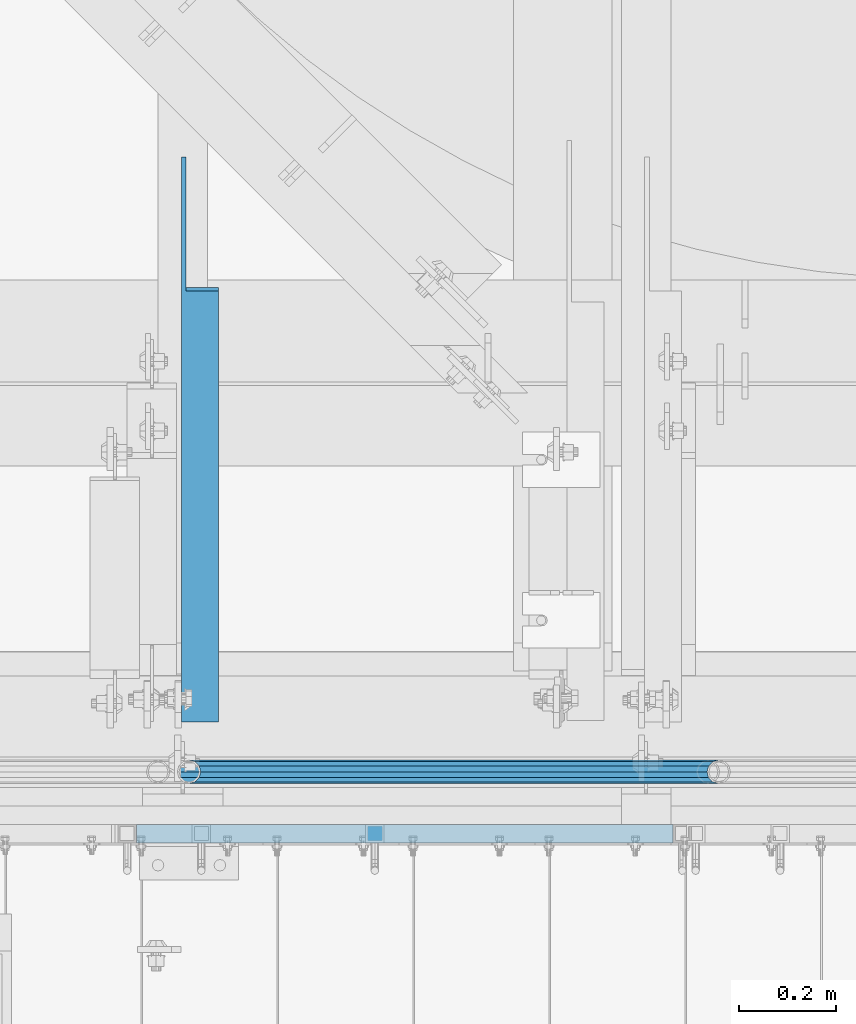
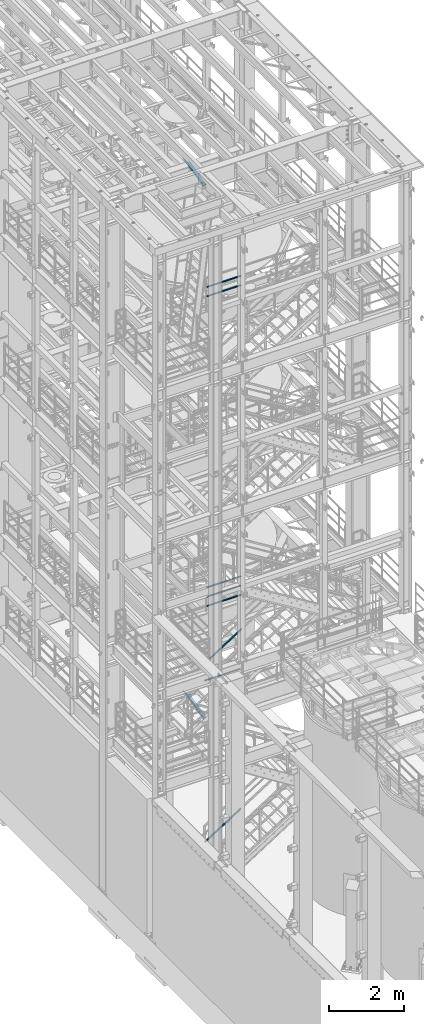
# One storey, part 969 of 1876: 8 beams, 2 members, 7 elements without a shape of their own.
"""IFC2X3 building model written with IfcOpenShell, lengths in millimetres."""

from ifc_helpers import new_model, si_unit, frame, origin_with_axes, place, context, subcontext, project, spatial, faceted_brep, material, type_object, element, aggregate, save


model = new_model("IFC2X3")

# Units and contexts
model_context = context("Model", 3, precision=1e-05, world=origin_with_axes())
body_context = subcontext(model_context, "Body", "Model", "MODEL_VIEW")
ifc_project = project(units=[si_unit("LENGTHUNIT", "METRE", prefix="MILLI"), si_unit("AREAUNIT", "SQUARE_METRE"), si_unit("VOLUMEUNIT", "CUBIC_METRE"), si_unit("MASSUNIT", "GRAM", prefix="KILO"), si_unit("TIMEUNIT", "SECOND"), si_unit("PLANEANGLEUNIT", "RADIAN"), si_unit("SOLIDANGLEUNIT", "STERADIAN"), si_unit("THERMODYNAMICTEMPERATUREUNIT", "DEGREE_CELSIUS"), si_unit("LUMINOUSINTENSITYUNIT", "LUMEN")], contexts=[model_context])

# Site, building, storey
site_placement = place(None, origin_with_axes())
site = spatial("IfcSite", under=ifc_project, at=site_placement, CompositionType="ELEMENT")
building_placement = place(site_placement, origin_with_axes())
building = spatial("IfcBuilding", under=site, at=building_placement, Name="Undefined", CompositionType="ELEMENT")
storey_placement = place(building_placement, origin_with_axes())
storey = spatial("IfcBuildingStorey", under=building, at=storey_placement, Name="Undefined", CompositionType="ELEMENT", Elevation=0.0)

# Assembly, beam
assembly_1_placement = place(storey_placement, origin_with_axes())
assembly_1 = element("IfcElementAssembly", 1, at=assembly_1_placement, inside=storey, Name="RAIL", AssemblyPlace="NOTDEFINED", PredefinedType="RIGID_FRAME")
ifc_material_1 = material()
beam_type_1 = type_object("IfcBeamType", Name="PIPE1-1/2SCH40", PredefinedType="NOTDEFINED")
beam_1_placement = place(assembly_1_placement, frame((2870.19999998823, -4654.55000114554, 18449.925), z_axis=(0.0, 0.0, -1.0), x_axis=(1.0, 0.0, 0.0)))
beam_1 = element("IfcBeam", 2, at=beam_1_placement, type_object=beam_type_1, material=ifc_material_1, Name="RAIL", ObjectType="PIPE1-1/2SCH40", context=body_context, shape_type="Brep", body=[
    faceted_brep([(0.0, 24.1299999999992, 0.0), (12.0650000000064, 20.8971929933177, -12.0649999999987), (12.0650000000064, 20.8971929933177, 12.0649999999987), (12.0650000000064, -20.8971929933177, 12.0649999999987), (12.0650000000064, -20.8971929933177, -12.0649999999987), (0.0, -24.1299999999992, 0.0), (20.8971929933249, -12.0650000000005, 20.8971929933177), (20.8971929933249, -12.0650000000005, 15.8661214311796), (15.2545715621445, -17.7076214311801, 10.2235000000001), (12.5151929933249, -20.4470000000001, 0.0), (15.2545715621445, -17.7076214311801, -10.2235000000001), (20.8971929933249, -12.0650000000005, -15.8661214311796), (20.8971929933249, -12.0650000000005, -20.8971929933177), (24.1300000000063, 0.0, -20.4470000000001), (24.1300000000063, 0.0, -24.130000000001), (21.3906214311868, -10.2235000000001, -17.7076214311819), (21.3906214311868, 10.2235000000001, -17.7076214311819), (20.8971929933249, 12.0650000000005, -15.8661214311796), (20.8971929933249, 12.0650000000005, -20.8971929933177), (15.2545715621445, 17.7076214311801, -10.2235000000001), (12.5151929933249, 20.4470000000001, 0.0), (15.2545715621445, 17.7076214311801, 10.2235000000001), (20.8971929933249, 12.0650000000005, 15.8661214311796), (20.8971929933249, 12.0650000000005, 20.8971929933177), (21.3906214311868, 10.2235000000001, 17.7076214311819), (24.1300000000064, 0.0, 20.4470000000001), (24.1300000000064, 0.0, 24.130000000001), (21.3906214311868, -10.2235000000001, 17.7076214311819), (1089.02499998822, 24.1300000000001, 0.0), (1076.95999998821, 20.8971929933186, -12.0650000000005), (1068.12780699489, 12.0649999999996, -20.8971929933177), (1089.02499998821, -24.1299999999865, 0.0), (1076.95999998821, -20.8971929933186, -12.0650000000005), (1076.95999998821, -20.8971929933186, 12.0650000000005), (1068.12780699489, -12.0649999999996, 20.8971929933177), (1068.12780699489, -12.0649999999996, -20.8971929933177), (1064.89499998821, 0.0, -24.1299999999992), (1067.63437855703, 10.2235000000001, -17.7076214311801), (1064.89499998821, 0.0, -20.4470000000001), (1068.12780699489, 12.0650000000132, -15.8661214311669), (1068.12780699489, -12.064999999986, -15.8661214311942), (1067.63437855703, -10.2235000000001, -17.7076214311801), (1073.77042842609, -17.7076214311801, -10.2235000000001), (1076.50980699491, -20.4470000000001, 0.0), (1073.77042842609, -17.7076214311801, 10.2235000000001), (1068.12780699489, -12.064999999986, 15.8661214311942), (1067.63437855703, -10.2235000000001, 17.7076214311801), (1064.89499998821, 0.0, 20.4470000000001), (1064.89499998821, 0.0, 24.1299999999992), (1068.12780699489, 12.0649999999996, 20.8971929933177), (1076.95999998821, 20.8971929933186, 12.0650000000005), (1068.12780699489, 12.0650000000132, 15.8661214311669), (1073.77042842606, 17.7076214311801, 10.2235000000001), (1076.50980699488, 20.4470000000001, 0.0), (1073.77042842606, 17.7076214311801, -10.2235000000001), (1067.63437855703, 10.2235000000001, 17.7076214311801)], [[[0, 1, 2]], [[3, 4, 5]], [[6, 7, 8, 9, 10, 11, 12, 4, 3]], [[13, 14, 12, 11, 15]], [[16, 17, 18, 14, 13]], [[2, 1, 18, 17, 19, 20, 21, 22, 23]], [[23, 22, 24, 25, 26]], [[26, 25, 27, 7, 6]], [[1, 0, 28, 29]], [[18, 1, 29, 30]], [[31, 32, 33]], [[6, 3, 33, 34]], [[3, 5, 31, 33]], [[5, 4, 32, 31]], [[4, 12, 35, 32]], [[12, 14, 36, 35]], [[14, 18, 30, 36]], [[37, 38, 36, 30, 39]], [[40, 35, 36, 38, 41]], [[33, 32, 35, 40, 42, 43, 44, 45, 34]], [[34, 45, 46, 47, 48]], [[26, 6, 34, 48]], [[2, 23, 49, 50]], [[23, 26, 48, 49]], [[0, 2, 50, 28]], [[28, 50, 29]], [[49, 51, 52, 53, 54, 39, 30, 29, 50]], [[48, 47, 55, 51, 49]], [[25, 24, 55, 47]], [[55, 24, 22, 21, 52, 51]], [[21, 20, 53, 52]], [[20, 19, 54, 53]], [[19, 17, 16, 37, 39, 54]], [[16, 13, 38, 37]], [[13, 15, 41, 38]], [[41, 15, 11, 10, 42, 40]], [[10, 9, 43, 42]], [[9, 8, 44, 43]], [[8, 7, 27, 46, 45, 44]], [[27, 25, 47, 46]]]),
])

# Assembly, beams
assembly_2_placement = place(storey_placement, origin_with_axes())
assembly_2 = element("IfcElementAssembly", 3, at=assembly_2_placement, inside=storey, Name="RAIL", AssemblyPlace="NOTDEFINED", PredefinedType="RIGID_FRAME")
beam_2_placement = place(assembly_2_placement, frame((3959.22499997646, -4654.55000114554, 8315.325), z_axis=(0.0, 0.0, 1.0), x_axis=(-1.0, 0.0, 0.0)))
beam_2 = element("IfcBeam", 4, at=beam_2_placement, type_object=beam_type_1, material=ifc_material_1, Name="RAIL", ObjectType="PIPE1-1/2SCH40", context=body_context, shape_type="Brep", body=[
    faceted_brep([(1068.12780699489, -12.0649999999996, 20.8971929933177), (1068.12780699489, -12.064999999986, 15.8661214311942), (1067.63437855703, -10.2235000000001, 17.7076214311801), (1064.89499998821, 0.0, 20.4470000000001), (1064.89499998821, 0.0, 24.1299999999992), (1067.63437855703, 10.2235000000001, 17.7076214311801), (1068.12780699489, 12.0650000000132, 15.8661214311669), (1068.12780699489, 12.0649999999996, 20.8971929933177), (1089.02499998822, 24.1300000000001, 0.0), (1076.95999998821, 20.8971929933186, 12.0650000000005), (1076.95999998821, 20.8971929933186, -12.0650000000005), (1073.77042842606, 17.7076214311801, 10.2235000000001), (1076.50980699488, 20.4470000000001, 0.0), (1073.77042842606, 17.7076214311801, -10.2235000000001), (1068.12780699489, 12.0650000000132, -15.8661214311669), (1068.12780699489, 12.0649999999996, -20.8971929933177), (1067.63437855703, 10.2235000000001, -17.7076214311801), (1064.89499998821, 0.0, -20.4470000000001), (1064.89499998821, 0.0, -24.1299999999992), (1068.12780699489, -12.064999999986, -15.8661214311942), (1068.12780699489, -12.0649999999996, -20.8971929933177), (1067.63437855703, -10.2235000000001, -17.7076214311801), (1089.02499998821, -24.1299999999865, 0.0), (1076.95999998821, -20.8971929933186, -12.0650000000005), (1076.95999998821, -20.8971929933186, 12.0650000000005), (1073.77042842609, -17.7076214311801, -10.2235000000001), (1076.50980699491, -20.4470000000001, 0.0), (1073.77042842609, -17.7076214311801, 10.2235000000001), (12.0650000000064, -20.8971929933177, -12.0649999999987), (20.8971929933249, -12.0650000000005, -20.8971929933177), (0.0, 24.1299999999992, 0.0), (12.0650000000064, 20.8971929933177, -12.0649999999987), (12.0650000000064, 20.8971929933177, 12.0649999999987), (20.8971929933249, 12.0650000000005, 20.8971929933177), (24.1300000000064, 0.0, 24.130000000001), (20.8971929933249, 12.0650000000005, -20.8971929933177), (24.1300000000063, 0.0, -24.130000000001), (24.1300000000063, 0.0, -20.4470000000001), (20.8971929933249, -12.0650000000005, -15.8661214311796), (21.3906214311868, -10.2235000000001, -17.7076214311819), (21.3906214311868, 10.2235000000001, -17.7076214311819), (20.8971929933249, 12.0650000000005, -15.8661214311796), (15.2545715621445, 17.7076214311801, -10.2235000000001), (12.5151929933249, 20.4470000000001, 0.0), (15.2545715621445, 17.7076214311801, 10.2235000000001), (20.8971929933249, 12.0650000000005, 15.8661214311796), (21.3906214311868, 10.2235000000001, 17.7076214311819), (24.1300000000064, 0.0, 20.4470000000001), (21.3906214311868, -10.2235000000001, 17.7076214311819), (20.8971929933249, -12.0650000000005, 15.8661214311796), (20.8971929933249, -12.0650000000005, 20.8971929933177), (12.0650000000064, -20.8971929933177, 12.0649999999987), (0.0, -24.1299999999992, 0.0), (15.2545715621445, -17.7076214311801, 10.2235000000001), (12.5151929933249, -20.4470000000001, 0.0), (15.2545715621445, -17.7076214311801, -10.2235000000001)], [[[0, 1, 2, 3, 4]], [[4, 3, 5, 6, 7]], [[8, 9, 10]], [[7, 6, 11, 12, 13, 14, 15, 10, 9]], [[16, 17, 18, 15, 14]], [[19, 20, 18, 17, 21]], [[22, 23, 24]], [[24, 23, 20, 19, 25, 26, 27, 1, 0]], [[28, 29, 20, 23]], [[30, 31, 32]], [[33, 34, 4, 7]], [[32, 33, 7, 9]], [[30, 32, 9, 8]], [[31, 30, 8, 10]], [[35, 31, 10, 15]], [[36, 35, 15, 18]], [[29, 36, 18, 20]], [[37, 36, 29, 38, 39]], [[40, 41, 35, 36, 37]], [[32, 31, 35, 41, 42, 43, 44, 45, 33]], [[33, 45, 46, 47, 34]], [[34, 47, 48, 49, 50]], [[34, 50, 0, 4]], [[50, 51, 24, 0]], [[51, 52, 22, 24]], [[52, 28, 23, 22]], [[51, 28, 52]], [[50, 49, 53, 54, 55, 38, 29, 28, 51]], [[55, 54, 26, 25]], [[21, 39, 38, 55, 25, 19]], [[37, 39, 21, 17]], [[40, 37, 17, 16]], [[42, 41, 40, 16, 14, 13]], [[43, 42, 13, 12]], [[44, 43, 12, 11]], [[5, 46, 45, 44, 11, 6]], [[47, 46, 5, 3]], [[48, 47, 3, 2]], [[53, 49, 48, 2, 1, 27]], [[54, 53, 27, 26]]]),
])
beam_3_placement = place(assembly_2_placement, frame((2870.19999998823, -4654.55000114554, 8620.125), z_axis=(0.0, 0.0, -1.0), x_axis=(1.0, 0.0, 0.0)))
beam_3 = element("IfcBeam", 5, at=beam_3_placement, type_object=beam_type_1, material=ifc_material_1, Name="RAIL", ObjectType="PIPE1-1/2SCH40", context=body_context, shape_type="Brep", body=[
    faceted_brep([(0.0, 24.1299999999992, 0.0), (12.0650000000064, 20.8971929933177, -12.0649999999987), (12.0650000000064, 20.8971929933177, 12.0649999999987), (12.0650000000064, -20.8971929933177, 12.0649999999987), (12.0650000000064, -20.8971929933177, -12.0649999999987), (0.0, -24.1299999999992, 0.0), (20.8971929933249, -12.0650000000005, 20.8971929933177), (20.8971929933249, -12.0650000000005, 15.8661214311796), (15.2545715621445, -17.7076214311801, 10.2235000000001), (12.5151929933249, -20.4470000000001, 0.0), (15.2545715621445, -17.7076214311801, -10.2235000000001), (20.8971929933249, -12.0650000000005, -15.8661214311796), (20.8971929933249, -12.0650000000005, -20.8971929933177), (24.1300000000063, 0.0, -20.4470000000001), (24.1300000000063, 0.0, -24.130000000001), (21.3906214311868, -10.2235000000001, -17.7076214311819), (21.3906214311868, 10.2235000000001, -17.7076214311819), (20.8971929933249, 12.0650000000005, -15.8661214311796), (20.8971929933249, 12.0650000000005, -20.8971929933177), (15.2545715621445, 17.7076214311801, -10.2235000000001), (12.5151929933249, 20.4470000000001, 0.0), (15.2545715621445, 17.7076214311801, 10.2235000000001), (20.8971929933249, 12.0650000000005, 15.8661214311796), (20.8971929933249, 12.0650000000005, 20.8971929933177), (21.3906214311868, 10.2235000000001, 17.7076214311819), (24.1300000000064, 0.0, 20.4470000000001), (24.1300000000064, 0.0, 24.130000000001), (21.3906214311868, -10.2235000000001, 17.7076214311819), (1089.02499998822, 24.1300000000001, 0.0), (1076.95999998821, 20.8971929933186, -12.0650000000005), (1068.12780699489, 12.0649999999996, -20.8971929933177), (1089.02499998821, -24.1299999999865, 0.0), (1076.95999998821, -20.8971929933186, -12.0650000000005), (1076.95999998821, -20.8971929933186, 12.0650000000005), (1068.12780699489, -12.0649999999996, 20.8971929933177), (1068.12780699489, -12.0649999999996, -20.8971929933177), (1064.89499998821, 0.0, -24.1299999999992), (1067.63437855703, 10.2235000000001, -17.7076214311801), (1064.89499998821, 0.0, -20.4470000000001), (1068.12780699489, 12.0650000000132, -15.8661214311669), (1068.12780699489, -12.064999999986, -15.8661214311942), (1067.63437855703, -10.2235000000001, -17.7076214311801), (1073.77042842609, -17.7076214311801, -10.2235000000001), (1076.50980699491, -20.4470000000001, 0.0), (1073.77042842609, -17.7076214311801, 10.2235000000001), (1068.12780699489, -12.064999999986, 15.8661214311942), (1067.63437855703, -10.2235000000001, 17.7076214311801), (1064.89499998821, 0.0, 20.4470000000001), (1064.89499998821, 0.0, 24.1299999999992), (1068.12780699489, 12.0649999999996, 20.8971929933177), (1076.95999998821, 20.8971929933186, 12.0650000000005), (1068.12780699489, 12.0650000000132, 15.8661214311669), (1073.77042842606, 17.7076214311801, 10.2235000000001), (1076.50980699488, 20.4470000000001, 0.0), (1073.77042842606, 17.7076214311801, -10.2235000000001), (1067.63437855703, 10.2235000000001, 17.7076214311801)], [[[0, 1, 2]], [[3, 4, 5]], [[6, 7, 8, 9, 10, 11, 12, 4, 3]], [[13, 14, 12, 11, 15]], [[16, 17, 18, 14, 13]], [[2, 1, 18, 17, 19, 20, 21, 22, 23]], [[23, 22, 24, 25, 26]], [[26, 25, 27, 7, 6]], [[1, 0, 28, 29]], [[18, 1, 29, 30]], [[31, 32, 33]], [[6, 3, 33, 34]], [[3, 5, 31, 33]], [[5, 4, 32, 31]], [[4, 12, 35, 32]], [[12, 14, 36, 35]], [[14, 18, 30, 36]], [[37, 38, 36, 30, 39]], [[40, 35, 36, 38, 41]], [[33, 32, 35, 40, 42, 43, 44, 45, 34]], [[34, 45, 46, 47, 48]], [[26, 6, 34, 48]], [[2, 23, 49, 50]], [[23, 26, 48, 49]], [[0, 2, 50, 28]], [[28, 50, 29]], [[49, 51, 52, 53, 54, 39, 30, 29, 50]], [[48, 47, 55, 51, 49]], [[25, 24, 55, 47]], [[55, 24, 22, 21, 52, 51]], [[21, 20, 53, 52]], [[20, 19, 54, 53]], [[19, 17, 16, 37, 39, 54]], [[16, 13, 38, 37]], [[13, 15, 41, 38]], [[41, 15, 11, 10, 42, 40]], [[10, 9, 43, 42]], [[9, 8, 44, 43]], [[8, 7, 27, 46, 45, 44]], [[27, 25, 47, 46]]]),
])
beam_4_placement = place(assembly_2_placement, frame((2870.19999998823, -4654.55000114554, 8924.925), z_axis=(0.0, 0.0, -1.0), x_axis=(1.0, 0.0, 0.0)))
beam_4 = element("IfcBeam", 6, at=beam_4_placement, type_object=beam_type_1, material=ifc_material_1, Name="RAIL", ObjectType="PIPE1-1/2SCH40", context=body_context, shape_type="Brep", body=[
    faceted_brep([(0.0, 24.1299999999992, 0.0), (12.0650000000064, 20.8971929933177, -12.0649999999987), (12.0650000000064, 20.8971929933177, 12.0649999999987), (12.0650000000064, -20.8971929933177, 12.0649999999987), (12.0650000000064, -20.8971929933177, -12.0649999999987), (0.0, -24.1299999999992, 0.0), (20.8971929933249, -12.0650000000005, 20.8971929933177), (20.8971929933249, -12.0650000000005, 15.8661214311796), (15.2545715621445, -17.7076214311801, 10.2235000000001), (12.5151929933249, -20.4470000000001, 0.0), (15.2545715621445, -17.7076214311801, -10.2235000000001), (20.8971929933249, -12.0650000000005, -15.8661214311796), (20.8971929933249, -12.0650000000005, -20.8971929933177), (24.1300000000063, 0.0, -20.4470000000001), (24.1300000000063, 0.0, -24.130000000001), (21.3906214311868, -10.2235000000001, -17.7076214311819), (21.3906214311868, 10.2235000000001, -17.7076214311819), (20.8971929933249, 12.0650000000005, -15.8661214311796), (20.8971929933249, 12.0650000000005, -20.8971929933177), (15.2545715621445, 17.7076214311801, -10.2235000000001), (12.5151929933249, 20.4470000000001, 0.0), (15.2545715621445, 17.7076214311801, 10.2235000000001), (20.8971929933249, 12.0650000000005, 15.8661214311796), (20.8971929933249, 12.0650000000005, 20.8971929933177), (21.3906214311868, 10.2235000000001, 17.7076214311819), (24.1300000000064, 0.0, 20.4470000000001), (24.1300000000064, 0.0, 24.130000000001), (21.3906214311868, -10.2235000000001, 17.7076214311819), (1089.02499998822, 24.1300000000001, 0.0), (1076.95999998821, 20.8971929933186, -12.0650000000005), (1068.12780699489, 12.0649999999996, -20.8971929933177), (1089.02499998821, -24.1299999999865, 0.0), (1076.95999998821, -20.8971929933186, -12.0650000000005), (1076.95999998821, -20.8971929933186, 12.0650000000005), (1068.12780699489, -12.0649999999996, 20.8971929933177), (1068.12780699489, -12.0649999999996, -20.8971929933177), (1064.89499998821, 0.0, -24.1299999999992), (1067.63437855703, 10.2235000000001, -17.7076214311801), (1064.89499998821, 0.0, -20.4470000000001), (1068.12780699489, 12.0650000000132, -15.8661214311669), (1068.12780699489, -12.064999999986, -15.8661214311942), (1067.63437855703, -10.2235000000001, -17.7076214311801), (1073.77042842609, -17.7076214311801, -10.2235000000001), (1076.50980699491, -20.4470000000001, 0.0), (1073.77042842609, -17.7076214311801, 10.2235000000001), (1068.12780699489, -12.064999999986, 15.8661214311942), (1067.63437855703, -10.2235000000001, 17.7076214311801), (1064.89499998821, 0.0, 20.4470000000001), (1064.89499998821, 0.0, 24.1299999999992), (1068.12780699489, 12.0649999999996, 20.8971929933177), (1076.95999998821, 20.8971929933186, 12.0650000000005), (1068.12780699489, 12.0650000000132, 15.8661214311669), (1073.77042842606, 17.7076214311801, 10.2235000000001), (1076.50980699488, 20.4470000000001, 0.0), (1073.77042842606, 17.7076214311801, -10.2235000000001), (1067.63437855703, 10.2235000000001, 17.7076214311801)], [[[0, 1, 2]], [[3, 4, 5]], [[6, 7, 8, 9, 10, 11, 12, 4, 3]], [[13, 14, 12, 11, 15]], [[16, 17, 18, 14, 13]], [[2, 1, 18, 17, 19, 20, 21, 22, 23]], [[23, 22, 24, 25, 26]], [[26, 25, 27, 7, 6]], [[1, 0, 28, 29]], [[18, 1, 29, 30]], [[31, 32, 33]], [[6, 3, 33, 34]], [[3, 5, 31, 33]], [[5, 4, 32, 31]], [[4, 12, 35, 32]], [[12, 14, 36, 35]], [[14, 18, 30, 36]], [[37, 38, 36, 30, 39]], [[40, 35, 36, 38, 41]], [[33, 32, 35, 40, 42, 43, 44, 45, 34]], [[34, 45, 46, 47, 48]], [[26, 6, 34, 48]], [[2, 23, 49, 50]], [[23, 26, 48, 49]], [[0, 2, 50, 28]], [[28, 50, 29]], [[49, 51, 52, 53, 54, 39, 30, 29, 50]], [[48, 47, 55, 51, 49]], [[25, 24, 55, 47]], [[55, 24, 22, 21, 52, 51]], [[21, 20, 53, 52]], [[20, 19, 54, 53]], [[19, 17, 16, 37, 39, 54]], [[16, 13, 38, 37]], [[13, 15, 41, 38]], [[41, 15, 11, 10, 42, 40]], [[10, 9, 43, 42]], [[9, 8, 44, 43]], [[8, 7, 27, 46, 45, 44]], [[27, 25, 47, 46]]]),
])
aggregate(assembly_2, [beam_2, beam_3, beam_4])

# Beam
beam_5_placement = place(assembly_1_placement, frame((2870.19999998823, -4654.55000114554, 18754.725), z_axis=(0.0, 0.0, -1.0), x_axis=(1.0, 0.0, 0.0)))
beam_5 = element("IfcBeam", 7, at=beam_5_placement, type_object=beam_type_1, material=ifc_material_1, Name="RAIL", ObjectType="PIPE1-1/2SCH40", context=body_context, shape_type="Brep", body=[
    faceted_brep([(0.0, 24.1299999999992, 0.0), (12.0650000000064, 20.8971929933177, -12.0649999999987), (12.0650000000064, 20.8971929933177, 12.0649999999987), (12.0650000000064, -20.8971929933177, 12.0649999999987), (12.0650000000064, -20.8971929933177, -12.0649999999987), (0.0, -24.1299999999992, 0.0), (20.8971929933249, -12.0650000000005, 20.8971929933177), (20.8971929933249, -12.0650000000005, 15.8661214311796), (15.2545715621445, -17.7076214311801, 10.2235000000001), (12.5151929933249, -20.4470000000001, 0.0), (15.2545715621445, -17.7076214311801, -10.2235000000001), (20.8971929933249, -12.0650000000005, -15.8661214311796), (20.8971929933249, -12.0650000000005, -20.8971929933177), (24.1300000000063, 0.0, -20.4470000000001), (24.1300000000063, 0.0, -24.130000000001), (21.3906214311868, -10.2235000000001, -17.7076214311819), (21.3906214311868, 10.2235000000001, -17.7076214311819), (20.8971929933249, 12.0650000000005, -15.8661214311796), (20.8971929933249, 12.0650000000005, -20.8971929933177), (15.2545715621445, 17.7076214311801, -10.2235000000001), (12.5151929933249, 20.4470000000001, 0.0), (15.2545715621445, 17.7076214311801, 10.2235000000001), (20.8971929933249, 12.0650000000005, 15.8661214311796), (20.8971929933249, 12.0650000000005, 20.8971929933177), (21.3906214311868, 10.2235000000001, 17.7076214311819), (24.1300000000064, 0.0, 20.4470000000001), (24.1300000000064, 0.0, 24.130000000001), (21.3906214311868, -10.2235000000001, 17.7076214311819), (1089.02499998822, 24.1300000000001, 0.0), (1076.95999998821, 20.8971929933186, -12.0650000000005), (1068.12780699489, 12.0649999999996, -20.8971929933177), (1089.02499998821, -24.1299999999865, 0.0), (1076.95999998821, -20.8971929933186, -12.0650000000005), (1076.95999998821, -20.8971929933186, 12.0650000000005), (1068.12780699489, -12.0649999999996, 20.8971929933177), (1068.12780699489, -12.0649999999996, -20.8971929933177), (1064.89499998821, 0.0, -24.1299999999992), (1067.63437855703, 10.2235000000001, -17.7076214311801), (1064.89499998821, 0.0, -20.4470000000001), (1068.12780699489, 12.0650000000132, -15.8661214311669), (1068.12780699489, -12.064999999986, -15.8661214311942), (1067.63437855703, -10.2235000000001, -17.7076214311801), (1073.77042842609, -17.7076214311801, -10.2235000000001), (1076.50980699491, -20.4470000000001, 0.0), (1073.77042842609, -17.7076214311801, 10.2235000000001), (1068.12780699489, -12.064999999986, 15.8661214311942), (1067.63437855703, -10.2235000000001, 17.7076214311801), (1064.89499998821, 0.0, 20.4470000000001), (1064.89499998821, 0.0, 24.1299999999992), (1068.12780699489, 12.0649999999996, 20.8971929933177), (1076.95999998821, 20.8971929933186, 12.0650000000005), (1068.12780699489, 12.0650000000132, 15.8661214311669), (1073.77042842606, 17.7076214311801, 10.2235000000001), (1076.50980699488, 20.4470000000001, 0.0), (1073.77042842606, 17.7076214311801, -10.2235000000001), (1067.63437855703, 10.2235000000001, 17.7076214311801)], [[[0, 1, 2]], [[3, 4, 5]], [[6, 7, 8, 9, 10, 11, 12, 4, 3]], [[13, 14, 12, 11, 15]], [[16, 17, 18, 14, 13]], [[2, 1, 18, 17, 19, 20, 21, 22, 23]], [[23, 22, 24, 25, 26]], [[26, 25, 27, 7, 6]], [[1, 0, 28, 29]], [[18, 1, 29, 30]], [[31, 32, 33]], [[6, 3, 33, 34]], [[3, 5, 31, 33]], [[5, 4, 32, 31]], [[4, 12, 35, 32]], [[12, 14, 36, 35]], [[14, 18, 30, 36]], [[37, 38, 36, 30, 39]], [[40, 35, 36, 38, 41]], [[33, 32, 35, 40, 42, 43, 44, 45, 34]], [[34, 45, 46, 47, 48]], [[26, 6, 34, 48]], [[2, 23, 49, 50]], [[23, 26, 48, 49]], [[0, 2, 50, 28]], [[28, 50, 29]], [[49, 51, 52, 53, 54, 39, 30, 29, 50]], [[48, 47, 55, 51, 49]], [[25, 24, 55, 47]], [[55, 24, 22, 21, 52, 51]], [[21, 20, 53, 52]], [[20, 19, 54, 53]], [[19, 17, 16, 37, 39, 54]], [[16, 13, 38, 37]], [[13, 15, 41, 38]], [[41, 15, 11, 10, 42, 40]], [[10, 9, 43, 42]], [[9, 8, 44, 43]], [[8, 7, 27, 46, 45, 44]], [[27, 25, 47, 46]]]),
])

aggregate(assembly_1, [beam_1, beam_5])

# Assembly, beam
assembly_3_placement = place(storey_placement, origin_with_axes())
assembly_3 = element("IfcElementAssembly", 8, at=assembly_3_placement, inside=storey, Name="RAIL", AssemblyPlace="NOTDEFINED", PredefinedType="RIGID_FRAME")
beam_6_placement = place(assembly_3_placement, frame((3937.00000015569, -4654.55000114549, 5902.325), z_axis=(0.0, 0.0, -1.0), x_axis=(-1.0, 0.0, 0.0)))
beam_6 = element("IfcBeam", 9, at=beam_6_placement, type_object=beam_type_1, material=ifc_material_1, Name="RAIL", ObjectType="PIPE1-1/2SCH40", context=body_context, shape_type="Brep", body=[
    faceted_brep([(0.0, 24.1299999999992, 0.0), (12.0650000000064, 20.8971929933177, -12.0649999999987), (12.0650000000064, 20.8971929933177, 12.0649999999987), (12.0650000000064, -20.8971929933177, 12.0649999999987), (12.0650000000064, -20.8971929933177, -12.0649999999987), (0.0, -24.1299999999992, 0.0), (20.8971929933249, -12.0650000000005, 20.8971929933177), (20.8971929933249, -12.0650000000005, 15.8661214311796), (15.2545715621445, -17.7076214311801, 10.2235000000001), (12.5151929933249, -20.4470000000001, 0.0), (15.2545715621445, -17.7076214311801, -10.2235000000001), (20.8971929933249, -12.0650000000005, -15.8661214311796), (20.8971929933249, -12.0650000000005, -20.8971929933177), (24.1300000000063, 0.0, -20.4470000000001), (24.1300000000063, 0.0, -24.130000000001), (21.3906214311868, -10.2235000000001, -17.7076214311819), (21.3906214311868, 10.2235000000001, -17.7076214311819), (20.8971929933249, 12.0650000000005, -15.8661214311796), (20.8971929933249, 12.0650000000005, -20.8971929933177), (15.2545715621445, 17.7076214311801, -10.2235000000001), (12.5151929933249, 20.4470000000001, 0.0), (15.2545715621445, 17.7076214311801, 10.2235000000001), (20.8971929933249, 12.0650000000005, 15.8661214311796), (20.8971929933249, 12.0650000000005, 20.8971929933177), (21.3906214311868, 10.2235000000001, 17.7076214311819), (24.1300000000064, 0.0, 20.4470000000001), (24.1300000000064, 0.0, 24.130000000001), (21.3906214311868, -10.2235000000001, 17.7076214311819), (1130.29999992215, 24.1300000000001, 0.0), (1118.23499992216, 20.8971929933186, -12.0649999999996), (1109.40280692884, 12.0649999999996, -20.8971929933186), (1130.29999992216, -24.1300000000274, 0.0), (1118.23499992216, -20.8971929933186, -12.0649999999996), (1118.23499992216, -20.8971929933186, 12.0649999999996), (1109.40280692884, -12.0649999999996, 20.8971929933186), (1109.40280692884, -12.0649999999996, -20.8971929933186), (1106.16999992216, 0.0, -24.1300000000001), (1108.90937849099, 10.2235000000001, -17.7076214311801), (1106.16999992216, 0.0, -20.4470000000001), (1109.40280692884, 12.0649999999723, -15.8661214312078), (1109.40280692884, -12.0650000000269, -15.8661214311533), (1108.90937849097, -10.2235000000001, -17.7076214311801), (1115.04542835999, -17.7076214311801, -10.2235000000001), (1117.78480692881, -20.4470000000001, 0.0), (1115.04542835999, -17.7076214311801, 10.2235000000001), (1109.40280692884, -12.0650000000269, 15.8661214311533), (1108.90937849097, -10.2235000000001, 17.7076214311801), (1106.16999992216, -9.09494701772928e-13, 20.4470000000001), (1106.16999992216, -9.09494701772928e-13, 24.1300000000001), (1109.40280692884, 12.0649999999996, 20.8971929933186), (1118.23499992216, 20.8971929933186, 12.0649999999996), (1109.40280692884, 12.0649999999723, 15.8661214312078), (1115.04542836005, 17.7076214311801, 10.2235000000001), (1117.78480692887, 20.4470000000001, 0.0), (1115.04542836005, 17.7076214311801, -10.2235000000001), (1108.90937849099, 10.2235000000001, 17.7076214311801)], [[[0, 1, 2]], [[3, 4, 5]], [[6, 7, 8, 9, 10, 11, 12, 4, 3]], [[13, 14, 12, 11, 15]], [[16, 17, 18, 14, 13]], [[2, 1, 18, 17, 19, 20, 21, 22, 23]], [[23, 22, 24, 25, 26]], [[26, 25, 27, 7, 6]], [[1, 0, 28, 29]], [[18, 1, 29, 30]], [[31, 32, 33]], [[6, 3, 33, 34]], [[3, 5, 31, 33]], [[5, 4, 32, 31]], [[4, 12, 35, 32]], [[12, 14, 36, 35]], [[14, 18, 30, 36]], [[37, 38, 36, 30, 39]], [[40, 35, 36, 38, 41]], [[33, 32, 35, 40, 42, 43, 44, 45, 34]], [[34, 45, 46, 47, 48]], [[26, 6, 34, 48]], [[2, 23, 49, 50]], [[23, 26, 48, 49]], [[0, 2, 50, 28]], [[28, 50, 29]], [[49, 51, 52, 53, 54, 39, 30, 29, 50]], [[48, 47, 55, 51, 49]], [[25, 24, 55, 47]], [[55, 24, 22, 21, 52, 51]], [[21, 20, 53, 52]], [[20, 19, 54, 53]], [[19, 17, 16, 37, 39, 54]], [[16, 13, 38, 37]], [[13, 15, 41, 38]], [[41, 15, 11, 10, 42, 40]], [[10, 9, 43, 42]], [[9, 8, 44, 43]], [[8, 7, 27, 46, 45, 44]], [[27, 25, 47, 46]]]),
])
aggregate(assembly_3, [beam_6])

assembly_4_placement = place(storey_placement, origin_with_axes())
assembly_4 = element("IfcElementAssembly", 10, at=assembly_4_placement, inside=storey, AssemblyPlace="NOTDEFINED", PredefinedType="RIGID_FRAME")
ifc_material_2 = material(Name="STEEL/A36")
beam_type_2 = type_object("IfcBeamType", Name="L3X3X3/8", PredefinedType="NOTDEFINED")
beam_7_placement = place(assembly_4_placement, frame((2892.425, -4562.3143433578, 4558.96418871958), z_axis=(1.0, 0.0, 0.0), x_axis=(0.0, 0.967147277703795, 0.254216724922138)))
beam_7 = element("IfcBeam", 11, at=beam_7_placement, type_object=beam_type_2, material=ifc_material_2, ObjectType="L3X3X3/8", context=body_context, shape_type="Brep", body=[
    faceted_brep([(23.7928828385348, 38.099999999994, -38.1000000000004), (23.7928828385348, 38.099999999994, 38.1000000000004), (905.477403464634, 38.1000000000176, 38.1000000000004), (905.477403464634, 38.1000000000176, -38.1000000000004), (23.7809703256453, 28.5749999999953, 38.1000000000004), (941.714507152235, 28.5750000000207, 38.1000000000004), (23.7809703256453, 28.5749999999953, -28.5749999999998), (941.714507152235, 28.5750000000207, -28.5749999999998), (23.6975827354227, -38.0999999999913, -28.5749999999998), (1195.37423296544, -38.0999999999585, -28.5749999999998), (23.6975827354227, -38.0999999999913, -38.1000000000004), (1195.37423296544, -38.0999999999585, -38.1000000000004)], [[[0, 1, 2, 3]], [[1, 4, 5, 2]], [[4, 6, 7, 5]], [[6, 8, 9, 7]], [[8, 10, 11, 9]], [[10, 0, 3, 11]], [[5, 7, 9, 11, 3, 2]], [[10, 8, 6, 4, 1, 0]]]),
])
aggregate(assembly_4, [beam_7])

assembly_5_placement = place(storey_placement, origin_with_axes())
assembly_5 = element("IfcElementAssembly", 12, at=assembly_5_placement, inside=storey, AssemblyPlace="NOTDEFINED", PredefinedType="RIGID_FRAME")
beam_8_placement = place(assembly_5_placement, frame((2892.42500019074, -4562.78281844778, 21997.5317219592), z_axis=(1.0, 0.0, 0.0), x_axis=(0.0, 0.97029600569138, 0.241920774923019)))
beam_8 = element("IfcBeam", 13, at=beam_8_placement, type_object=beam_type_2, material=ifc_material_2, ObjectType="L3X3X3/8", context=body_context, shape_type="Brep", body=[
    faceted_brep([(20.4512332895073, 38.1000000000495, -38.0999999999999), (20.4512332895073, 38.1000000000495, 38.0999999999999), (892.440924395522, 38.0999999997366, 38.0999999999999), (892.440924395522, 38.0999999997366, -38.0999999999999), (20.4512332895037, 28.5750000000371, 38.0999999999999), (930.643800759319, 28.5749999997061, 38.0999999999999), (20.4512332895037, 28.5750000000371, -28.575), (930.643800759319, 28.5749999997061, -28.575), (20.4512332894728, -38.1000000000604, -28.575), (1198.0639353059, -38.1000000004824, -28.575), (20.4512332894728, -38.1000000000604, -38.0999999999999), (1198.0639353059, -38.1000000004824, -38.0999999999999)], [[[0, 1, 2, 3]], [[1, 4, 5, 2]], [[4, 6, 7, 5]], [[6, 8, 9, 7]], [[8, 10, 11, 9]], [[10, 0, 3, 11]], [[5, 7, 9, 11, 3, 2]], [[10, 8, 6, 4, 1, 0]]]),
])
aggregate(assembly_5, [beam_8])

# Assembly, member
assembly_6_placement = place(storey_placement, origin_with_axes())
assembly_6 = element("IfcElementAssembly", 14, at=assembly_6_placement, inside=storey, Name="RAIL", AssemblyPlace="NOTDEFINED", PredefinedType="RIGID_FRAME")
ifc_material_3 = material()
member_type = type_object("IfcMemberType", Name="HSS1-1/2X1-1/2X1/8", PredefinedType="NOTDEFINED")
member_1_placement = place(assembly_6_placement, frame((2895.60000031066, -4781.55000114554, 6659.70681758197), z_axis=(-0.536875491934336, 0.0, 0.843661487896813), x_axis=(0.843661487896813, 0.0, 0.536875491934336)))
member_1 = element("IfcMember", 15, at=member_1_placement, type_object=member_type, material=ifc_material_3, Name="RAIL", ObjectType="HSS1-1/2X1-1/2X1/8", context=body_context, shape_type="Brep", body=[
    faceted_brep([(1193.81705789482, -19.0499992349996, 19.0499992351256), (1169.57160433941, -19.0499992349996, -19.04999923487), (1169.57160433941, 19.0499992349996, -19.04999923487), (1193.81705789482, 19.0499992349996, 19.0499992351256), (1191.79660338128, -15.8749992829999, 15.8749992831263), (1191.79660338128, 15.8749992829999, 15.8749992831263), (1171.59205885295, 15.8749992829999, -15.8749992828712), (1171.59205885295, -15.8749992829999, -15.8749992828712), (10.4574188235219, 19.0499992349996, -19.0499992349946), (34.7028723789208, 19.0499992349996, 19.0499992350083), (34.7028723789208, -19.0499992349996, 19.0499992350083), (10.4574188235219, -19.0499992349996, -19.0499992349946), (32.6824178653787, 15.8749992829999, 15.8749992830085), (32.6824178653787, -15.8749992829999, 15.8749992830085), (12.4778733370622, -15.8749992829999, -15.8749992829939), (12.4778733370622, 15.8749992829999, -15.8749992829939)], [[[0, 1, 2, 3], [4, 5, 6, 7]], [[3, 2, 8, 9]], [[0, 3, 9, 10]], [[1, 0, 10, 11]], [[2, 1, 11, 8]], [[11, 10, 9, 8], [12, 13, 14, 15]], [[4, 7, 14, 13]], [[7, 6, 15, 14]], [[6, 5, 12, 15]], [[5, 4, 13, 12]]]),
])
aggregate(assembly_6, [member_1])

assembly_7_placement = place(storey_placement, origin_with_axes())
assembly_7 = element("IfcElementAssembly", 16, at=assembly_7_placement, inside=storey, Name="RAIL", AssemblyPlace="NOTDEFINED", PredefinedType="RIGID_FRAME")
member_2_placement = place(assembly_7_placement, frame((2743.20000001392, -4781.55000114554, 710.652585995029), z_axis=(-0.53569741975471, 0.0, 0.844410015613355), x_axis=(0.844410015326383, 0.0, 0.535697420207059)))
member_2 = element("IfcMember", 17, at=member_2_placement, type_object=member_type, material=ifc_material_3, Name="RAIL", ObjectType="HSS1-1/2X1-1/2X1/8", context=body_context, shape_type="Brep", body=[
    faceted_brep([(1340.78307962549, -19.0499992349996, 19.0499992350333), (1316.61227338722, -19.0499992349996, -19.0499992349723), (1316.61227338722, 19.0499992349996, -19.0499992349723), (1340.78307962549, 19.0499992349996, 19.0499992350333), (1338.76884572186, -15.8749992829999, 15.8749992830328), (1338.76884572186, 15.8749992829999, 15.8749992830328), (1318.62650729085, 15.8749992829999, -15.8749992829719), (1318.62650729085, -15.8749992829999, -15.8749992829719), (34.6455325374254, 19.0499992349996, 19.049999235012), (34.6455325374254, -19.0499992349996, 19.049999235012), (10.4747262991696, -19.0499992349996, -19.0499992349991), (10.4747262991696, 19.0499992349996, -19.0499992349991), (32.6312986338025, 15.8749992829999, 15.8749992830109), (32.6312986338025, -15.8749992829999, 15.8749992830109), (12.4889602027924, -15.8749992829999, -15.8749992829981), (12.4889602027924, 15.8749992829999, -15.8749992829981)], [[[0, 1, 2, 3], [4, 5, 6, 7]], [[0, 3, 8, 9]], [[2, 1, 10, 11]], [[1, 0, 9, 10]], [[3, 2, 11, 8]], [[10, 9, 8, 11], [12, 13, 14, 15]], [[4, 7, 14, 13]], [[7, 6, 15, 14]], [[6, 5, 12, 15]], [[5, 4, 13, 12]]]),
])
aggregate(assembly_7, [member_2])

save(model, "model.ifc")
